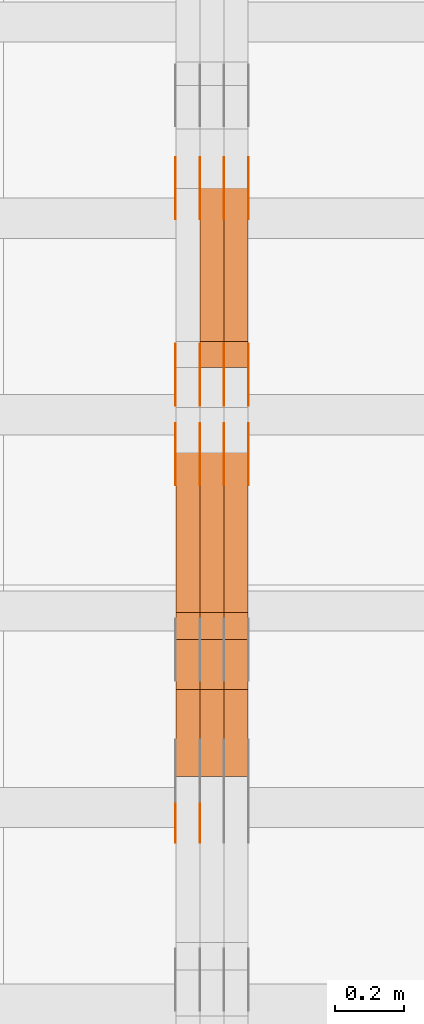
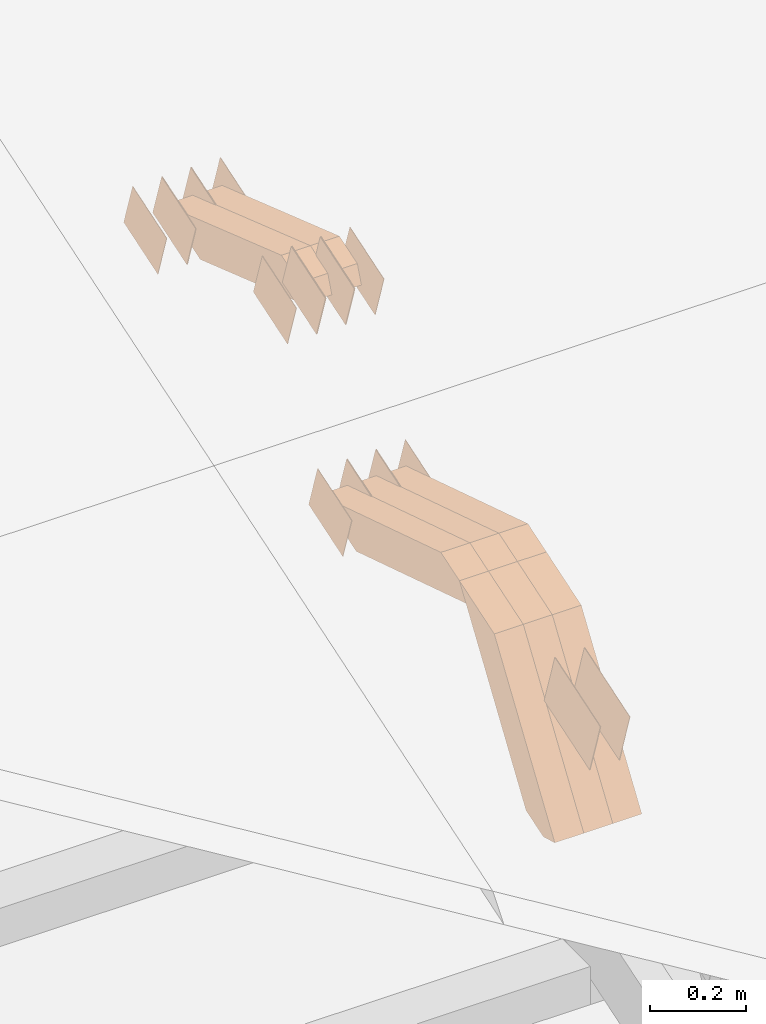
# One storey, part 127 of 385: 28 proxies.
"""IFC2X3 building model written with IfcOpenShell, lengths in millimetres."""

import ifcopenshell
import ifcopenshell.guid

model = None  # the IFC model being written
_history = None  # IfcOwnerHistory: only IFC2X3 demands one
_inside = {}  # id of a spatial element -> (the spatial element, [elements in it])
_under = {}  # id of a project, library or spatial element -> (it, [spatial elements below it])
_declared = {}  # id of a project -> (the project, [libraries it declares])
_typed = {}  # id of a type object -> (the type object, [elements of that type])
_made_of = {}  # id of a material, layer set ... -> (it, [elements and type objects made of it])


def new_model(schema):
    """Start an empty IFC model of exactly this schema.

    Asked for "IFC4X3", IfcOpenShell would pick the latest addendum, in which some entities
    have other attributes; the version numbers below select the first issue.
    IFC2X3 requires an IfcOwnerHistory on every rooted entity: one is made here for all.
    """
    global model, _history
    if schema == "IFC4X3":
        model = ifcopenshell.file(schema_version=(4, 3, 0, 0))
    else:
        model = ifcopenshell.file(schema=schema)
    _inside.clear()
    _under.clear()
    _declared.clear()
    _typed.clear()
    _made_of.clear()
    _history = None
    if model.schema == "IFC2X3":
        org = make("IfcOrganization", Name="unknown")
        user = make(
            "IfcPersonAndOrganization",
            ThePerson=make("IfcPerson", FamilyName="unknown"),
            TheOrganization=org,
        )
        app = make(
            "IfcApplication",
            ApplicationDeveloper=org,
            Version="unknown",
            ApplicationFullName="unknown",
            ApplicationIdentifier="unknown",
        )
        _history = make(
            "IfcOwnerHistory",
            OwningUser=user,
            OwningApplication=app,
            ChangeAction="ADDED",
            CreationDate=0,
        )
    return model


def make(cls, **values):
    """One entity of the class cls with the attributes given. An attribute that is None is left unset."""
    return model.create_entity(
        cls, **{name: value for name, value in values.items() if value is not None}
    )


def entity(cls, *values):
    """Any entity or typed value of the class cls, its attributes in the order of the schema. None: left unset."""
    e = model.create_entity(cls)
    for i, value in enumerate(values):
        if value is not None:
            e[i] = value
    return e


def rooted(cls, **values):
    """An entity with a GlobalId (a new one), such as an element, a storey or a relation."""
    return make(cls, GlobalId=ifcopenshell.guid.new(), OwnerHistory=_history, **values)


def si_unit(unit_type, name, prefix=None):
    """IfcSIUnit, for example si_unit("LENGTHUNIT", "METRE", prefix="MILLI")."""
    return make("IfcSIUnit", UnitType=unit_type, Prefix=prefix, Name=name)


def converted_unit(unit_type, name, factor, base, dimensions=None, offset=None):
    """IfcConversionBasedUnit, such as the inch: factor (a typed value) times the base unit."""
    return make(
        "IfcConversionBasedUnit"
        if offset is None
        else "IfcConversionBasedUnitWithOffset",
        ConversionOffset=offset,
        Dimensions=None
        if dimensions is None
        else entity("IfcDimensionalExponents", *dimensions),
        UnitType=unit_type,
        Name=name,
        ConversionFactor=make(
            "IfcMeasureWithUnit", ValueComponent=factor, UnitComponent=base
        ),
    )


def derived_unit(unit_type, elements):
    """IfcDerivedUnit: a product of units, each with its exponent."""
    return make(
        "IfcDerivedUnit",
        Elements=[
            make("IfcDerivedUnitElement", Unit=unit, Exponent=power)
            for unit, power in elements
        ],
        UnitType=unit_type,
    )


def assignment(units):
    """IfcUnitAssignment: the units of a project."""
    return None if units is None else make("IfcUnitAssignment", Units=units)


def point(xyz):
    """IfcCartesianPoint."""
    return None if xyz is None else make("IfcCartesianPoint", Coordinates=xyz)


def direction(xyz):
    """IfcDirection."""
    return None if xyz is None else make("IfcDirection", DirectionRatios=xyz)


def frame(location, z_axis=None, x_axis=None):
    """IfcAxis2Placement3D, a coordinate frame: its origin and axes. An axis left out is left unset."""
    return make(
        "IfcAxis2Placement3D",
        Location=point(location),
        Axis=direction(z_axis),
        RefDirection=direction(x_axis),
    )


def origin():
    """The frame at (0, 0, 0) with its axes left unset."""
    return frame((0.0, 0.0, 0.0))


def place(relative_to, where):
    """IfcLocalPlacement: puts the frame where relative to a parent placement (None: the world)."""
    return make(
        "IfcLocalPlacement", PlacementRelTo=relative_to, RelativePlacement=where
    )


def context(
    kind, dimensions, precision=None, world=None, true_north=None, identifier=None
):
    """IfcGeometricRepresentationContext, for example the 3D "Model" context."""
    return make(
        "IfcGeometricRepresentationContext",
        ContextIdentifier=identifier,
        ContextType=kind,
        CoordinateSpaceDimension=dimensions,
        Precision=precision,
        WorldCoordinateSystem=world,
        TrueNorth=true_north,
    )


def subcontext(parent, identifier, kind, view, scale=None):
    """IfcGeometricRepresentationSubContext, for example "Body" below "Model"."""
    return make(
        "IfcGeometricRepresentationSubContext",
        ContextIdentifier=identifier,
        ContextType=kind,
        ParentContext=parent,
        TargetScale=scale,
        TargetView=view,
    )


def project(units=None, contexts=None):
    """IfcProject with its units and contexts."""
    return rooted(
        "IfcProject",
        Name="project",
        RepresentationContexts=contexts,
        UnitsInContext=assignment(units),
    )


def spatial(cls, under=None, at=None, **own):
    """A site, building, storey or space (cls), placed at a placement, below another one or the project."""
    s = rooted(cls, ObjectPlacement=at, **own)
    if under is not None:
        _under.setdefault(under.id(), (under, []))[1].append(s)
    return s


def polyline(points):
    """IfcPolyline through the points."""
    return make("IfcPolyline", Points=[point(p) for p in points])


def outline(outer, holes=None, kind="AREA"):
    """IfcArbitraryClosedProfileDef: a profile drawn as a closed curve; with holes, ...WithVoids."""
    if holes is None:
        return make("IfcArbitraryClosedProfileDef", ProfileType=kind, OuterCurve=outer)
    return make(
        "IfcArbitraryProfileDefWithVoids",
        ProfileType=kind,
        OuterCurve=outer,
        InnerCurves=holes,
    )


def extrude(swept, where, along, depth):
    """IfcExtrudedAreaSolid: the profile swept, set in the frame where, extruded along a direction by depth."""
    return make(
        "IfcExtrudedAreaSolid",
        SweptArea=swept,
        Position=where,
        ExtrudedDirection=direction(along),
        Depth=depth,
    )


def shape(context_of_items, identifier, shape_type, items):
    """IfcShapeRepresentation: the items that make up one representation, for example the "Body"."""
    return make(
        "IfcShapeRepresentation",
        ContextOfItems=context_of_items,
        RepresentationIdentifier=identifier,
        RepresentationType=shape_type,
        Items=items,
    )


def source(mapping_origin, context_of_items, identifier, shape_type, items):
    """IfcRepresentationMap: a shape defined once, which mapped items show again and again."""
    return make(
        "IfcRepresentationMap",
        MappingOrigin=mapping_origin,
        MappedRepresentation=shape(context_of_items, identifier, shape_type, items),
    )


def transform(
    local_origin,
    x_axis=None,
    y_axis=None,
    z_axis=None,
    scale=None,
    scale2=None,
    scale3=None,
    uniform=True,
):
    """IfcCartesianTransformationOperator3D, or its non-uniform kind. x_axis, y_axis, z_axis: its Axis1, 2, 3."""
    if uniform:
        return make(
            "IfcCartesianTransformationOperator3D",
            Axis1=direction(x_axis),
            Axis2=direction(y_axis),
            LocalOrigin=point(local_origin),
            Scale=scale,
            Axis3=direction(z_axis),
        )
    return make(
        "IfcCartesianTransformationOperator3DnonUniform",
        Axis1=direction(x_axis),
        Axis2=direction(y_axis),
        LocalOrigin=point(local_origin),
        Scale=scale,
        Axis3=direction(z_axis),
        Scale2=scale2,
        Scale3=scale3,
    )


def mapped(mapping_source, mapping_target):
    """IfcMappedItem: shows the shape of a source again, moved by a transform."""
    return make(
        "IfcMappedItem", MappingSource=mapping_source, MappingTarget=mapping_target
    )


def material(Name=None, Category=None):
    """IfcMaterial."""
    return make("IfcMaterial", Name=Name, Category=Category)


def made_of(thing, what):
    """Note that an element or type object is made of a material, layer set ...; save() writes the relation."""
    if what is not None:
        _made_of.setdefault(what.id(), (what, []))[1].append(thing)
    return thing


def type_object(cls, material=None, **own):
    """A type object (cls), such as IfcWallType, which elements share."""
    return made_of(rooted(cls, **own), material)


def type_shapes(of_type, sources):
    """Give a type object the sources (RepresentationMaps) that its elements show as mapped items."""
    of_type.RepresentationMaps = sources


def element(
    cls,
    number,
    at=None,
    inside=None,
    cuts=None,
    type_object=None,
    material=None,
    context=None,
    identifier="Body",
    shape_type=None,
    held_by="IfcProductDefinitionShape",
    body=None,
    shapes=None,
    **own,
):
    """One element of the class cls, such as IfcWall. Its Tag is "e" and its number.

    at: its placement. inside: the storey or other place that contains it. cuts: it is an
    opening in that element (IfcRelVoidsElement). A single representation is given by context,
    identifier, shape_type and body (its items); several are given by shapes. held_by: the class
    of the entity that holds the representations. save() writes the other relations.
    """
    e = rooted(cls, Tag="e%d" % number, ObjectPlacement=at, **own)
    if body is not None:
        shapes = [shape(context, identifier, shape_type, body)]
    if shapes is not None:
        e.Representation = make(held_by, Representations=shapes)
    if inside is not None:
        _inside.setdefault(inside.id(), (inside, []))[1].append(e)
    if cuts is not None:
        rooted(
            "IfcRelVoidsElement", RelatingBuildingElement=cuts, RelatedOpeningElement=e
        )
    if type_object is not None:
        _typed.setdefault(type_object.id(), (type_object, []))[1].append(e)
    return made_of(e, material)


def aggregate(whole, parts):
    """IfcRelAggregates: a whole, such as a stair, and the parts it consists of."""
    return rooted("IfcRelAggregates", RelatingObject=whole, RelatedObjects=parts)


def save(model, path):
    """Write the relations noted so far, then the file.

    IfcRelAggregates (storeys below a building ...), IfcRelContainedInSpatialStructure (elements
    in a storey), IfcRelDefinesByType, IfcRelAssociatesMaterial and IfcRelDeclares: one each for
    every whole, place, type object, material and project.
    """
    for whole, parts in _under.values():
        aggregate(whole, parts)
    for where, things in _inside.values():
        rooted(
            "IfcRelContainedInSpatialStructure",
            RelatedElements=things,
            RelatingStructure=where,
        )
    for kind, things in _typed.values():
        rooted("IfcRelDefinesByType", RelatedObjects=things, RelatingType=kind)
    for what, things in _made_of.values():
        rooted("IfcRelAssociatesMaterial", RelatedObjects=things, RelatingMaterial=what)
    for by, libraries in _declared.values():
        rooted("IfcRelDeclares", RelatingContext=by, RelatedDefinitions=libraries)
    model.write(path)


model = new_model("IFC2X3")

# Units and contexts
model_context = context("Model", 3, precision=0.01, world=origin(), true_north=direction((6.12303176911189e-17, 1.0)))
body_context = subcontext(model_context, "Body", "Model", "MODEL_VIEW")
ifc_project = project(units=[si_unit("LENGTHUNIT", "METRE", prefix="MILLI"), si_unit("AREAUNIT", "SQUARE_METRE"), si_unit("VOLUMEUNIT", "CUBIC_METRE"), converted_unit("PLANEANGLEUNIT", "DEGREE", entity("IfcRatioMeasure", 0.0174532925199433), si_unit("PLANEANGLEUNIT", "RADIAN"), dimensions=[0, 0, 0, 0, 0, 0, 0]), si_unit("MASSUNIT", "GRAM", prefix="KILO"), derived_unit("MASSDENSITYUNIT", [(si_unit("MASSUNIT", "GRAM", prefix="KILO"), 1), (si_unit("LENGTHUNIT", "METRE"), -3)]), si_unit("TIMEUNIT", "SECOND"), si_unit("FREQUENCYUNIT", "HERTZ"), si_unit("THERMODYNAMICTEMPERATUREUNIT", "DEGREE_CELSIUS"), derived_unit("THERMALTRANSMITTANCEUNIT", [(si_unit("MASSUNIT", "GRAM", prefix="KILO"), 1), (si_unit("THERMODYNAMICTEMPERATUREUNIT", "KELVIN"), -1), (si_unit("TIMEUNIT", "SECOND"), -3)]), derived_unit("VOLUMETRICFLOWRATEUNIT", [(si_unit("LENGTHUNIT", "METRE"), 3), (si_unit("TIMEUNIT", "SECOND"), -1)]), si_unit("ELECTRICCURRENTUNIT", "AMPERE"), si_unit("ELECTRICVOLTAGEUNIT", "VOLT"), si_unit("POWERUNIT", "WATT"), si_unit("FORCEUNIT", "NEWTON", prefix="KILO"), si_unit("ILLUMINANCEUNIT", "LUX"), si_unit("LUMINOUSFLUXUNIT", "LUMEN"), si_unit("LUMINOUSINTENSITYUNIT", "CANDELA"), derived_unit("USERDEFINED", [(si_unit("MASSUNIT", "GRAM", prefix="KILO"), -1), (si_unit("LENGTHUNIT", "METRE"), -2), (si_unit("TIMEUNIT", "SECOND"), 3), (si_unit("LUMINOUSFLUXUNIT", "LUMEN"), 1)]), derived_unit("LINEARVELOCITYUNIT", [(si_unit("LENGTHUNIT", "METRE"), 1), (si_unit("TIMEUNIT", "SECOND"), -1)]), si_unit("PRESSUREUNIT", "PASCAL"), derived_unit("USERDEFINED", [(si_unit("LENGTHUNIT", "METRE"), -2), (si_unit("MASSUNIT", "GRAM", prefix="KILO"), 1), (si_unit("TIMEUNIT", "SECOND"), -2)])], contexts=[model_context])

# Site, building, storey
site_placement = place(None, origin())
site = spatial("IfcSite", under=ifc_project, at=site_placement, CompositionType="ELEMENT")
building_placement = place(site_placement, origin())
building = spatial("IfcBuilding", under=site, at=building_placement, CompositionType="ELEMENT")
storey_placement = place(building_placement, origin())
storey = spatial("IfcBuildingStorey", under=building, at=storey_placement, Name="Default", CompositionType="ELEMENT", Elevation=0.0)

# Proxies
ifc_material_1 = material(Name="IfcSurfaceStyle #345158")
building_element_proxy_type_1 = type_object("IfcBuildingElementProxyType", PredefinedType="NOTDEFINED", material=ifc_material_1)
shared_shape_1 = source(origin(), body_context, "Body", "SweptSolid", [
    extrude(outline(polyline([(-74.9998754286198, -60.0000016373433), (74.9998605591145, -60.0000016373433), (74.999875428618, 60.0000016373433), (-74.9998605591127, 60.0000016373433), (-74.9998754286198, -60.0000016373433)])), frame((75.0007059026038, 60.000210935219, 0.0), z_axis=(0.0, 0.0, 1.0), x_axis=(-1.0, 0.0, 0.0)), (0.0, 0.0, 1.0), 1.3),
])
type_shapes(building_element_proxy_type_1, [shared_shape_1])
proxy_1_placement = place(building_placement, frame((27386.3, 6760.15341914203, 1372.60670336718), z_axis=(-1.0, 0.0, 0.0), x_axis=(0.0, 0.951056516295124, 0.309016994375039)))
element("IfcBuildingElementProxy", 1, at=proxy_1_placement, inside=storey, type_object=building_element_proxy_type_1, material=ifc_material_1, context=body_context, shape_type="MappedRepresentation", body=[
    mapped(shared_shape_1, transform((0.0, 0.0, 0.0), scale=1.0)),
])
ifc_material_2 = material(Name="IfcSurfaceStyle #345101")
building_element_proxy_type_2 = type_object("IfcBuildingElementProxyType", PredefinedType="NOTDEFINED", material=ifc_material_2)
shared_shape_2 = source(origin(), body_context, "Body", "SweptSolid", [
    extrude(outline(polyline([(-74.9998754286198, -60.0000016373433), (74.9998605591145, -60.0000016373433), (74.999875428618, 60.0000016373433), (-74.9998605591127, 60.0000016373433), (-74.9998754286198, -60.0000016373433)])), frame((75.0007059026038, 60.000210935219, 0.0), z_axis=(0.0, 0.0, 1.0), x_axis=(-1.0, 0.0, 0.0)), (0.0, 0.0, 1.0), 1.3),
])
type_shapes(building_element_proxy_type_2, [shared_shape_2])
proxy_2_placement = place(building_placement, frame((27315.0, 6760.15341914203, 1372.60670336718), z_axis=(-1.0, 0.0, 0.0), x_axis=(0.0, 0.951056516295124, 0.309016994375039)))
element("IfcBuildingElementProxy", 2, at=proxy_2_placement, inside=storey, type_object=building_element_proxy_type_2, material=ifc_material_2, context=body_context, shape_type="MappedRepresentation", body=[
    mapped(shared_shape_2, transform((0.0, 0.0, 0.0), scale=1.0)),
])
ifc_material_3 = material(Name="IfcSurfaceStyle #345044")
building_element_proxy_type_3 = type_object("IfcBuildingElementProxyType", PredefinedType="NOTDEFINED", material=ifc_material_3)
shared_shape_3 = source(origin(), body_context, "Body", "SweptSolid", [
    extrude(outline(polyline([(-74.9998754286198, -60.0000016373433), (74.9998605591145, -60.0000016373433), (74.999875428618, 60.0000016373433), (-74.9998605591127, 60.0000016373433), (-74.9998754286198, -60.0000016373433)])), frame((75.0007059026038, 60.000210935219, 0.0), z_axis=(0.0, 0.0, 1.0), x_axis=(-1.0, 0.0, 0.0)), (0.0, 0.0, 1.0), 1.3),
])
type_shapes(building_element_proxy_type_3, [shared_shape_3])
proxy_3_placement = place(building_placement, frame((27316.3, 6760.15341914203, 1372.60670336718), z_axis=(-1.0, 0.0, 0.0), x_axis=(0.0, 0.951056516295124, 0.309016994375039)))
element("IfcBuildingElementProxy", 3, at=proxy_3_placement, inside=storey, type_object=building_element_proxy_type_3, material=ifc_material_3, context=body_context, shape_type="MappedRepresentation", body=[
    mapped(shared_shape_3, transform((0.0, 0.0, 0.0), scale=1.0)),
])
ifc_material_4 = material(Name="IfcSurfaceStyle #344987")
building_element_proxy_type_4 = type_object("IfcBuildingElementProxyType", PredefinedType="NOTDEFINED", material=ifc_material_4)
shared_shape_4 = source(origin(), body_context, "Body", "SweptSolid", [
    extrude(outline(polyline([(-74.9998754286198, -60.0000016373433), (74.9998605591145, -60.0000016373433), (74.999875428618, 60.0000016373433), (-74.9998605591127, 60.0000016373433), (-74.9998754286198, -60.0000016373433)])), frame((75.0007059026038, 60.000210935219, 0.0), z_axis=(0.0, 0.0, 1.0), x_axis=(-1.0, 0.0, 0.0)), (0.0, 0.0, 1.0), 1.29999999999999),
])
type_shapes(building_element_proxy_type_4, [shared_shape_4])
proxy_4_placement = place(building_placement, frame((27245.0, 6760.15341914203, 1372.60670336718), z_axis=(-1.0, 0.0, 0.0), x_axis=(0.0, 0.951056516295124, 0.309016994375039)))
element("IfcBuildingElementProxy", 4, at=proxy_4_placement, inside=storey, type_object=building_element_proxy_type_4, material=ifc_material_4, context=body_context, shape_type="MappedRepresentation", body=[
    mapped(shared_shape_4, transform((0.0, 0.0, 0.0), scale=1.0)),
])
ifc_material_5 = material(Name="IfcSurfaceStyle #344930")
building_element_proxy_type_5 = type_object("IfcBuildingElementProxyType", PredefinedType="NOTDEFINED", material=ifc_material_5)
shared_shape_5 = source(origin(), body_context, "Body", "SweptSolid", [
    extrude(outline(polyline([(-74.9998754286198, -60.0000016373433), (74.9998605591145, -60.0000016373433), (74.999875428618, 60.0000016373433), (-74.9998605591127, 60.0000016373433), (-74.9998754286198, -60.0000016373433)])), frame((75.0007059026038, 60.000210935219, 0.0), z_axis=(0.0, 0.0, 1.0), x_axis=(-1.0, 0.0, 0.0)), (0.0, 0.0, 1.0), 1.29999999999999),
])
type_shapes(building_element_proxy_type_5, [shared_shape_5])
proxy_5_placement = place(building_placement, frame((27246.3, 6760.15341914203, 1372.60670336718), z_axis=(-1.0, 0.0, 0.0), x_axis=(0.0, 0.951056516295124, 0.309016994375039)))
element("IfcBuildingElementProxy", 5, at=proxy_5_placement, inside=storey, type_object=building_element_proxy_type_5, material=ifc_material_5, context=body_context, shape_type="MappedRepresentation", body=[
    mapped(shared_shape_5, transform((0.0, 0.0, 0.0), scale=1.0)),
])
ifc_material_6 = material(Name="IfcSurfaceStyle #344873")
building_element_proxy_type_6 = type_object("IfcBuildingElementProxyType", PredefinedType="NOTDEFINED", material=ifc_material_6)
shared_shape_6 = source(origin(), body_context, "Body", "SweptSolid", [
    extrude(outline(polyline([(-74.9998754286198, -60.0000016373433), (74.9998605591145, -60.0000016373433), (74.999875428618, 60.0000016373433), (-74.9998605591127, 60.0000016373433), (-74.9998754286198, -60.0000016373433)])), frame((75.0007059026038, 60.000210935219, 0.0), z_axis=(0.0, 0.0, 1.0), x_axis=(-1.0, 0.0, 0.0)), (0.0, 0.0, 1.0), 1.29999999999999),
])
type_shapes(building_element_proxy_type_6, [shared_shape_6])
proxy_6_placement = place(building_placement, frame((27175.0, 6760.15341914203, 1372.60670336718), z_axis=(-1.0, 0.0, 0.0), x_axis=(0.0, 0.951056516295124, 0.309016994375039)))
element("IfcBuildingElementProxy", 6, at=proxy_6_placement, inside=storey, type_object=building_element_proxy_type_6, material=ifc_material_6, context=body_context, shape_type="MappedRepresentation", body=[
    mapped(shared_shape_6, transform((0.0, 0.0, 0.0), scale=1.0)),
])
ifc_material_7 = material(Name="IfcSurfaceStyle #339002")
building_element_proxy_type_7 = type_object("IfcBuildingElementProxyType", PredefinedType="NOTDEFINED", material=ifc_material_7)
shared_shape_7 = source(origin(), body_context, "Body", "SweptSolid", [
    extrude(outline(polyline([(-74.9998801438441, -60.0000306612856), (74.9998747047876, -60.0000306612856), (74.9998707133936, 60.0000306612856), (-74.9998652743371, 60.0000306612856), (-74.9998801438441, -60.0000306612856)])), frame((75.0000206139493, 60.0000306612856, 0.0), z_axis=(0.0, 0.0, 1.0), x_axis=(-1.0, 0.0, 0.0)), (0.0, 0.0, 1.0), 1.3),
])
type_shapes(building_element_proxy_type_7, [shared_shape_7])
proxy_7_placement = place(building_placement, frame((27386.3, 5987.08381858242, 1121.42116774683), z_axis=(-1.0, 0.0, 0.0), x_axis=(0.0, 0.951056516295124, 0.309016994375039)))
element("IfcBuildingElementProxy", 7, at=proxy_7_placement, inside=storey, type_object=building_element_proxy_type_7, material=ifc_material_7, context=body_context, shape_type="MappedRepresentation", body=[
    mapped(shared_shape_7, transform((0.0, 0.0, 0.0), scale=1.0)),
])
ifc_material_8 = material(Name="IfcSurfaceStyle #338945")
building_element_proxy_type_8 = type_object("IfcBuildingElementProxyType", PredefinedType="NOTDEFINED", material=ifc_material_8)
shared_shape_8 = source(origin(), body_context, "Body", "SweptSolid", [
    extrude(outline(polyline([(-74.9998801438441, -60.0000306612856), (74.9998747047876, -60.0000306612856), (74.9998707133936, 60.0000306612856), (-74.9998652743371, 60.0000306612856), (-74.9998801438441, -60.0000306612856)])), frame((75.0000206139493, 60.0000306612856, 0.0), z_axis=(0.0, 0.0, 1.0), x_axis=(-1.0, 0.0, 0.0)), (0.0, 0.0, 1.0), 1.3),
])
type_shapes(building_element_proxy_type_8, [shared_shape_8])
proxy_8_placement = place(building_placement, frame((27315.0, 5987.08381858242, 1121.42116774683), z_axis=(-1.0, 0.0, 0.0), x_axis=(0.0, 0.951056516295124, 0.309016994375039)))
element("IfcBuildingElementProxy", 8, at=proxy_8_placement, inside=storey, type_object=building_element_proxy_type_8, material=ifc_material_8, context=body_context, shape_type="MappedRepresentation", body=[
    mapped(shared_shape_8, transform((0.0, 0.0, 0.0), scale=1.0)),
])
ifc_material_9 = material(Name="IfcSurfaceStyle #338888")
building_element_proxy_type_9 = type_object("IfcBuildingElementProxyType", PredefinedType="NOTDEFINED", material=ifc_material_9)
shared_shape_9 = source(origin(), body_context, "Body", "SweptSolid", [
    extrude(outline(polyline([(-74.9998801438441, -60.0000306612856), (74.9998747047876, -60.0000306612856), (74.9998707133936, 60.0000306612856), (-74.9998652743371, 60.0000306612856), (-74.9998801438441, -60.0000306612856)])), frame((75.0000206139493, 60.0000306612856, 0.0), z_axis=(0.0, 0.0, 1.0), x_axis=(-1.0, 0.0, 0.0)), (0.0, 0.0, 1.0), 1.3),
])
type_shapes(building_element_proxy_type_9, [shared_shape_9])
proxy_9_placement = place(building_placement, frame((27316.3, 5987.08381858242, 1121.42116774683), z_axis=(-1.0, 0.0, 0.0), x_axis=(0.0, 0.951056516295124, 0.309016994375039)))
element("IfcBuildingElementProxy", 9, at=proxy_9_placement, inside=storey, type_object=building_element_proxy_type_9, material=ifc_material_9, context=body_context, shape_type="MappedRepresentation", body=[
    mapped(shared_shape_9, transform((0.0, 0.0, 0.0), scale=1.0)),
])
ifc_material_10 = material(Name="IfcSurfaceStyle #338831")
building_element_proxy_type_10 = type_object("IfcBuildingElementProxyType", PredefinedType="NOTDEFINED", material=ifc_material_10)
shared_shape_10 = source(origin(), body_context, "Body", "SweptSolid", [
    extrude(outline(polyline([(-74.9998801438441, -60.0000306612856), (74.9998747047876, -60.0000306612856), (74.9998707133936, 60.0000306612856), (-74.9998652743371, 60.0000306612856), (-74.9998801438441, -60.0000306612856)])), frame((75.0000206139493, 60.0000306612856, 0.0), z_axis=(0.0, 0.0, 1.0), x_axis=(-1.0, 0.0, 0.0)), (0.0, 0.0, 1.0), 1.29999999999999),
])
type_shapes(building_element_proxy_type_10, [shared_shape_10])
proxy_10_placement = place(building_placement, frame((27245.0, 5987.08381858242, 1121.42116774683), z_axis=(-1.0, 0.0, 0.0), x_axis=(0.0, 0.951056516295124, 0.309016994375039)))
element("IfcBuildingElementProxy", 10, at=proxy_10_placement, inside=storey, type_object=building_element_proxy_type_10, material=ifc_material_10, context=body_context, shape_type="MappedRepresentation", body=[
    mapped(shared_shape_10, transform((0.0, 0.0, 0.0), scale=1.0)),
])
ifc_material_11 = material(Name="IfcSurfaceStyle #338774")
building_element_proxy_type_11 = type_object("IfcBuildingElementProxyType", PredefinedType="NOTDEFINED", material=ifc_material_11)
shared_shape_11 = source(origin(), body_context, "Body", "SweptSolid", [
    extrude(outline(polyline([(-74.9998801438441, -60.0000306612856), (74.9998747047876, -60.0000306612856), (74.9998707133936, 60.0000306612856), (-74.9998652743371, 60.0000306612856), (-74.9998801438441, -60.0000306612856)])), frame((75.0000206139493, 60.0000306612856, 0.0), z_axis=(0.0, 0.0, 1.0), x_axis=(-1.0, 0.0, 0.0)), (0.0, 0.0, 1.0), 1.29999999999999),
])
type_shapes(building_element_proxy_type_11, [shared_shape_11])
proxy_11_placement = place(building_placement, frame((27246.3, 5987.08381858242, 1121.42116774683), z_axis=(-1.0, 0.0, 0.0), x_axis=(0.0, 0.951056516295124, 0.309016994375039)))
element("IfcBuildingElementProxy", 11, at=proxy_11_placement, inside=storey, type_object=building_element_proxy_type_11, material=ifc_material_11, context=body_context, shape_type="MappedRepresentation", body=[
    mapped(shared_shape_11, transform((0.0, 0.0, 0.0), scale=1.0)),
])
ifc_material_12 = material(Name="IfcSurfaceStyle #338717")
building_element_proxy_type_12 = type_object("IfcBuildingElementProxyType", PredefinedType="NOTDEFINED", material=ifc_material_12)
shared_shape_12 = source(origin(), body_context, "Body", "SweptSolid", [
    extrude(outline(polyline([(-74.9998801438441, -60.0000306612856), (74.9998747047876, -60.0000306612856), (74.9998707133936, 60.0000306612856), (-74.9998652743371, 60.0000306612856), (-74.9998801438441, -60.0000306612856)])), frame((75.0000206139493, 60.0000306612856, 0.0), z_axis=(0.0, 0.0, 1.0), x_axis=(-1.0, 0.0, 0.0)), (0.0, 0.0, 1.0), 1.29999999999999),
])
type_shapes(building_element_proxy_type_12, [shared_shape_12])
proxy_12_placement = place(building_placement, frame((27175.0, 5987.08381858242, 1121.42116774683), z_axis=(-1.0, 0.0, 0.0), x_axis=(0.0, 0.951056516295124, 0.309016994375039)))
element("IfcBuildingElementProxy", 12, at=proxy_12_placement, inside=storey, type_object=building_element_proxy_type_12, material=ifc_material_12, context=body_context, shape_type="MappedRepresentation", body=[
    mapped(shared_shape_12, transform((0.0, 0.0, 0.0), scale=1.0)),
])
ifc_material_13 = material(Name="IfcSurfaceStyle #334556")
building_element_proxy_type_13 = type_object("IfcBuildingElementProxyType", PredefinedType="NOTDEFINED", material=ifc_material_13)
shared_shape_13 = source(origin(), body_context, "Body", "SweptSolid", [
    extrude(outline(polyline([(-74.9998754286253, -60.0000016373506), (74.999860559109, -60.0000016373506), (74.9998754286235, 60.0000016373506), (-74.9998605591072, 60.0000016373506), (-74.9998754286253, -60.0000016373506)])), frame((75.0001009411744, 60.0000279841752, 0.0), z_axis=(0.0, 0.0, 1.0), x_axis=(-1.0, 0.0, 0.0)), (0.0, 0.0, 1.0), 1.3),
])
type_shapes(building_element_proxy_type_13, [shared_shape_13])
proxy_13_placement = place(building_placement, frame((27386.3, 6218.29662915452, 1523.23574463408), z_axis=(-1.0, 0.0, 0.0), x_axis=(0.0, 0.951056516295154, 0.309016994374948)))
element("IfcBuildingElementProxy", 13, at=proxy_13_placement, inside=storey, type_object=building_element_proxy_type_13, material=ifc_material_13, context=body_context, shape_type="MappedRepresentation", body=[
    mapped(shared_shape_13, transform((0.0, 0.0, 0.0), scale=1.0)),
])
ifc_material_14 = material(Name="IfcSurfaceStyle #334499")
building_element_proxy_type_14 = type_object("IfcBuildingElementProxyType", PredefinedType="NOTDEFINED", material=ifc_material_14)
shared_shape_14 = source(origin(), body_context, "Body", "SweptSolid", [
    extrude(outline(polyline([(-74.9998754286253, -60.0000016373506), (74.999860559109, -60.0000016373506), (74.9998754286235, 60.0000016373506), (-74.9998605591072, 60.0000016373506), (-74.9998754286253, -60.0000016373506)])), frame((75.0001009411744, 60.0000279841752, 0.0), z_axis=(0.0, 0.0, 1.0), x_axis=(-1.0, 0.0, 0.0)), (0.0, 0.0, 1.0), 1.3),
])
type_shapes(building_element_proxy_type_14, [shared_shape_14])
proxy_14_placement = place(building_placement, frame((27315.0, 6218.29662915452, 1523.23574463408), z_axis=(-1.0, 0.0, 0.0), x_axis=(0.0, 0.951056516295154, 0.309016994374948)))
element("IfcBuildingElementProxy", 14, at=proxy_14_placement, inside=storey, type_object=building_element_proxy_type_14, material=ifc_material_14, context=body_context, shape_type="MappedRepresentation", body=[
    mapped(shared_shape_14, transform((0.0, 0.0, 0.0), scale=1.0)),
])
ifc_material_15 = material(Name="IfcSurfaceStyle #334442")
building_element_proxy_type_15 = type_object("IfcBuildingElementProxyType", PredefinedType="NOTDEFINED", material=ifc_material_15)
shared_shape_15 = source(origin(), body_context, "Body", "SweptSolid", [
    extrude(outline(polyline([(-74.9998754286253, -60.0000016373506), (74.999860559109, -60.0000016373506), (74.9998754286235, 60.0000016373506), (-74.9998605591072, 60.0000016373506), (-74.9998754286253, -60.0000016373506)])), frame((75.0001009411744, 60.0000279841752, 0.0), z_axis=(0.0, 0.0, 1.0), x_axis=(-1.0, 0.0, 0.0)), (0.0, 0.0, 1.0), 1.3),
])
type_shapes(building_element_proxy_type_15, [shared_shape_15])
proxy_15_placement = place(building_placement, frame((27316.3, 6218.29662915452, 1523.23574463408), z_axis=(-1.0, 0.0, 0.0), x_axis=(0.0, 0.951056516295154, 0.309016994374948)))
element("IfcBuildingElementProxy", 15, at=proxy_15_placement, inside=storey, type_object=building_element_proxy_type_15, material=ifc_material_15, context=body_context, shape_type="MappedRepresentation", body=[
    mapped(shared_shape_15, transform((0.0, 0.0, 0.0), scale=1.0)),
])
ifc_material_16 = material(Name="IfcSurfaceStyle #334385")
building_element_proxy_type_16 = type_object("IfcBuildingElementProxyType", PredefinedType="NOTDEFINED", material=ifc_material_16)
shared_shape_16 = source(origin(), body_context, "Body", "SweptSolid", [
    extrude(outline(polyline([(-74.9998754286253, -60.0000016373506), (74.999860559109, -60.0000016373506), (74.9998754286235, 60.0000016373506), (-74.9998605591072, 60.0000016373506), (-74.9998754286253, -60.0000016373506)])), frame((75.0001009411744, 60.0000279841752, 0.0), z_axis=(0.0, 0.0, 1.0), x_axis=(-1.0, 0.0, 0.0)), (0.0, 0.0, 1.0), 1.29999999999999),
])
type_shapes(building_element_proxy_type_16, [shared_shape_16])
proxy_16_placement = place(building_placement, frame((27245.0, 6218.29662915452, 1523.23574463408), z_axis=(-1.0, 0.0, 0.0), x_axis=(0.0, 0.951056516295154, 0.309016994374948)))
element("IfcBuildingElementProxy", 16, at=proxy_16_placement, inside=storey, type_object=building_element_proxy_type_16, material=ifc_material_16, context=body_context, shape_type="MappedRepresentation", body=[
    mapped(shared_shape_16, transform((0.0, 0.0, 0.0), scale=1.0)),
])
ifc_material_17 = material(Name="IfcSurfaceStyle #334328")
building_element_proxy_type_17 = type_object("IfcBuildingElementProxyType", PredefinedType="NOTDEFINED", material=ifc_material_17)
shared_shape_17 = source(origin(), body_context, "Body", "SweptSolid", [
    extrude(outline(polyline([(-74.9998754286253, -60.0000016373506), (74.999860559109, -60.0000016373506), (74.9998754286235, 60.0000016373506), (-74.9998605591072, 60.0000016373506), (-74.9998754286253, -60.0000016373506)])), frame((75.0001009411744, 60.0000279841752, 0.0), z_axis=(0.0, 0.0, 1.0), x_axis=(-1.0, 0.0, 0.0)), (0.0, 0.0, 1.0), 1.29999999999999),
])
type_shapes(building_element_proxy_type_17, [shared_shape_17])
proxy_17_placement = place(building_placement, frame((27246.3, 6218.29662915452, 1523.23574463408), z_axis=(-1.0, 0.0, 0.0), x_axis=(0.0, 0.951056516295154, 0.309016994374948)))
element("IfcBuildingElementProxy", 17, at=proxy_17_placement, inside=storey, type_object=building_element_proxy_type_17, material=ifc_material_17, context=body_context, shape_type="MappedRepresentation", body=[
    mapped(shared_shape_17, transform((0.0, 0.0, 0.0), scale=1.0)),
])
ifc_material_18 = material(Name="IfcSurfaceStyle #334271")
building_element_proxy_type_18 = type_object("IfcBuildingElementProxyType", PredefinedType="NOTDEFINED", material=ifc_material_18)
shared_shape_18 = source(origin(), body_context, "Body", "SweptSolid", [
    extrude(outline(polyline([(-74.9998754286253, -60.0000016373506), (74.999860559109, -60.0000016373506), (74.9998754286235, 60.0000016373506), (-74.9998605591072, 60.0000016373506), (-74.9998754286253, -60.0000016373506)])), frame((75.0001009411744, 60.0000279841752, 0.0), z_axis=(0.0, 0.0, 1.0), x_axis=(-1.0, 0.0, 0.0)), (0.0, 0.0, 1.0), 1.29999999999999),
])
type_shapes(building_element_proxy_type_18, [shared_shape_18])
proxy_18_placement = place(building_placement, frame((27175.0, 6218.29662915452, 1523.23574463408), z_axis=(-1.0, 0.0, 0.0), x_axis=(0.0, 0.951056516295154, 0.309016994374948)))
element("IfcBuildingElementProxy", 18, at=proxy_18_placement, inside=storey, type_object=building_element_proxy_type_18, material=ifc_material_18, context=body_context, shape_type="MappedRepresentation", body=[
    mapped(shared_shape_18, transform((0.0, 0.0, 0.0), scale=1.0)),
])
ifc_material_19 = material(Name="IfcSurfaceStyle #329882")
building_element_proxy_type_19 = type_object("IfcBuildingElementProxyType", PredefinedType="NOTDEFINED", material=ifc_material_19)
shared_shape_19 = source(origin(), body_context, "Body", "SweptSolid", [
    extrude(outline(polyline([(-99.9996257846169, -71.999973710258), (100.000009625089, -71.999973710258), (99.9996257846187, 71.999973710258), (-100.000009625091, 71.999973710258), (-99.9996257846169, -71.999973710258)])), frame((100.000083496635, 72.0000008245779, 0.0), z_axis=(0.0, 0.0, 1.0), x_axis=(-1.0, 0.0, 0.0)), (0.0, 0.0, 1.0), 1.29999999999998),
])
type_shapes(building_element_proxy_type_19, [shared_shape_19])
proxy_19_placement = place(building_placement, frame((27246.3, 4947.73195917317, 1225.53937157357), z_axis=(-1.0, 0.0, 0.0), x_axis=(0.0, 0.951056516295154, 0.309016994374948)))
element("IfcBuildingElementProxy", 19, at=proxy_19_placement, inside=storey, type_object=building_element_proxy_type_19, material=ifc_material_19, context=body_context, shape_type="MappedRepresentation", body=[
    mapped(shared_shape_19, transform((0.0, 0.0, 0.0), scale=1.0)),
])
ifc_material_20 = material(Name="IfcSurfaceStyle #329825")
building_element_proxy_type_20 = type_object("IfcBuildingElementProxyType", PredefinedType="NOTDEFINED", material=ifc_material_20)
shared_shape_20 = source(origin(), body_context, "Body", "SweptSolid", [
    extrude(outline(polyline([(-99.9996257846169, -71.999973710258), (100.000009625089, -71.999973710258), (99.9996257846187, 71.999973710258), (-100.000009625091, 71.999973710258), (-99.9996257846169, -71.999973710258)])), frame((100.000083496635, 72.0000008245779, 0.0), z_axis=(0.0, 0.0, 1.0), x_axis=(-1.0, 0.0, 0.0)), (0.0, 0.0, 1.0), 1.29999999999999),
])
type_shapes(building_element_proxy_type_20, [shared_shape_20])
proxy_20_placement = place(building_placement, frame((27175.0, 4947.73195917317, 1225.53937157357), z_axis=(-1.0, 0.0, 0.0), x_axis=(0.0, 0.951056516295154, 0.309016994374948)))
element("IfcBuildingElementProxy", 20, at=proxy_20_placement, inside=storey, type_object=building_element_proxy_type_20, material=ifc_material_20, context=body_context, shape_type="MappedRepresentation", body=[
    mapped(shared_shape_20, transform((0.0, 0.0, 0.0), scale=1.0)),
])
ifc_material_21 = material(Name="IfcSurfaceStyle #321560")
building_element_proxy_type_21 = type_object("IfcBuildingElementProxyType", Name="T1-W19 321558", PredefinedType="NOTDEFINED", material=ifc_material_21)
shared_shape_21 = source(origin(), body_context, "Body", "SweptSolid", [
    extrude(outline(polyline([(-234.986199656822, -47.5000587840676), (221.224626701627, -47.5000587840676), (219.29748584664, -9.04449542012076e-05), (156.014457007826, 47.5001040065446), (-361.550369899272, 47.5001040065447), (-234.986199656822, -47.5000587840676)])), frame((221.224626701627, 47.5001108598228, 0.0), z_axis=(0.0, 0.0, 1.0), x_axis=(-1.0, 0.0, 0.0)), (0.0, 0.0, 1.0), 70.0),
])
type_shapes(building_element_proxy_type_21, [shared_shape_21])
proxy_21_placement = place(building_placement, frame((27385.0, 6342.4042570111, 1541.63383639481), z_axis=(-1.0, 0.0, 0.0), x_axis=(0.0, 0.9461301511345, -0.323786561046329)))
element("IfcBuildingElementProxy", 21, at=proxy_21_placement, inside=storey, type_object=building_element_proxy_type_21, material=ifc_material_21, Name="T1-W19", context=body_context, shape_type="MappedRepresentation", body=[
    mapped(shared_shape_21, transform((0.0, 0.0, 0.0), scale=1.0)),
])
ifc_material_22 = material(Name="IfcSurfaceStyle #321494")
building_element_proxy_type_22 = type_object("IfcBuildingElementProxyType", Name="T1-W19 321492", PredefinedType="NOTDEFINED", material=ifc_material_22)
shared_shape_22 = source(origin(), body_context, "Body", "SweptSolid", [
    extrude(outline(polyline([(-234.986199656822, -47.5000587840676), (221.224626701627, -47.5000587840676), (219.29748584664, -9.04449542012076e-05), (156.014457007826, 47.5001040065446), (-361.550369899272, 47.5001040065447), (-234.986199656822, -47.5000587840676)])), frame((221.224626701627, 47.5001108598228, 0.0), z_axis=(0.0, 0.0, 1.0), x_axis=(-1.0, 0.0, 0.0)), (0.0, 0.0, 1.0), 70.0),
])
type_shapes(building_element_proxy_type_22, [shared_shape_22])
proxy_22_placement = place(building_placement, frame((27315.0, 6342.4042570111, 1541.63383639481), z_axis=(-1.0, 0.0, 0.0), x_axis=(0.0, 0.9461301511345, -0.323786561046329)))
element("IfcBuildingElementProxy", 22, at=proxy_22_placement, inside=storey, type_object=building_element_proxy_type_22, material=ifc_material_22, Name="T1-W19", context=body_context, shape_type="MappedRepresentation", body=[
    mapped(shared_shape_22, transform((0.0, 0.0, 0.0), scale=1.0)),
])
ifc_material_23 = material(Name="IfcSurfaceStyle #320768")
building_element_proxy_type_23 = type_object("IfcBuildingElementProxyType", Name="T1-W15 320766", PredefinedType="NOTDEFINED", material=ifc_material_23)
shared_shape_23 = source(origin(), body_context, "Body", "SweptSolid", [
    extrude(outline(polyline([(-243.398341390642, -47.5000170814535), (237.775741169608, -47.5000170814535), (224.054017709933, 0.000127777485579883), (157.692261395711, 47.4999531927108), (-376.12367888461, 47.4999531927107), (-243.398341390642, -47.5000170814535)])), frame((237.77637044506, 47.5003404768297, 0.0), z_axis=(0.0, 0.0, 1.0), x_axis=(-1.0, 0.0, 0.0)), (0.0, 0.0, 1.0), 70.0),
])
type_shapes(building_element_proxy_type_23, [shared_shape_23])
proxy_23_placement = place(building_placement, frame((27385.0, 5540.23242178142, 1288.84274826279), z_axis=(-1.0, 0.0, 0.0), x_axis=(0.0, 0.95322291386448, -0.302268219440466)))
element("IfcBuildingElementProxy", 23, at=proxy_23_placement, inside=storey, type_object=building_element_proxy_type_23, material=ifc_material_23, Name="T1-W15", context=body_context, shape_type="MappedRepresentation", body=[
    mapped(shared_shape_23, transform((0.0, 0.0, 0.0), scale=1.0)),
])
ifc_material_24 = material(Name="IfcSurfaceStyle #320702")
building_element_proxy_type_24 = type_object("IfcBuildingElementProxyType", Name="T1-W15 320700", PredefinedType="NOTDEFINED", material=ifc_material_24)
shared_shape_24 = source(origin(), body_context, "Body", "SweptSolid", [
    extrude(outline(polyline([(-243.398341390642, -47.5000170814535), (237.775741169608, -47.5000170814535), (224.054017709933, 0.000127777485579883), (157.692261395711, 47.4999531927108), (-376.12367888461, 47.4999531927107), (-243.398341390642, -47.5000170814535)])), frame((237.77637044506, 47.5003404768297, 0.0), z_axis=(0.0, 0.0, 1.0), x_axis=(-1.0, 0.0, 0.0)), (0.0, 0.0, 1.0), 70.0),
])
type_shapes(building_element_proxy_type_24, [shared_shape_24])
proxy_24_placement = place(building_placement, frame((27315.0, 5540.23242178142, 1288.84274826279), z_axis=(-1.0, 0.0, 0.0), x_axis=(0.0, 0.95322291386448, -0.302268219440466)))
element("IfcBuildingElementProxy", 24, at=proxy_24_placement, inside=storey, type_object=building_element_proxy_type_24, material=ifc_material_24, Name="T1-W15", context=body_context, shape_type="MappedRepresentation", body=[
    mapped(shared_shape_24, transform((0.0, 0.0, 0.0), scale=1.0)),
])
ifc_material_25 = material(Name="IfcSurfaceStyle #320636")
building_element_proxy_type_25 = type_object("IfcBuildingElementProxyType", Name="T1-W15 320634", PredefinedType="NOTDEFINED", material=ifc_material_25)
shared_shape_25 = source(origin(), body_context, "Body", "SweptSolid", [
    extrude(outline(polyline([(-243.398341390642, -47.5000170814535), (237.775741169608, -47.5000170814535), (224.054017709933, 0.000127777485579883), (157.692261395711, 47.4999531927108), (-376.12367888461, 47.4999531927107), (-243.398341390642, -47.5000170814535)])), frame((237.77637044506, 47.5003404768297, 0.0), z_axis=(0.0, 0.0, 1.0), x_axis=(-1.0, 0.0, 0.0)), (0.0, 0.0, 1.0), 70.0),
])
type_shapes(building_element_proxy_type_25, [shared_shape_25])
proxy_25_placement = place(building_placement, frame((27245.0, 5540.23242178142, 1288.84274826279), z_axis=(-1.0, 0.0, 0.0), x_axis=(0.0, 0.95322291386448, -0.302268219440466)))
element("IfcBuildingElementProxy", 25, at=proxy_25_placement, inside=storey, type_object=building_element_proxy_type_25, material=ifc_material_25, Name="T1-W15", context=body_context, shape_type="MappedRepresentation", body=[
    mapped(shared_shape_25, transform((0.0, 0.0, 0.0), scale=1.0)),
])
ifc_material_26 = material(Name="IfcSurfaceStyle #320372")
building_element_proxy_type_26 = type_object("IfcBuildingElementProxyType", Name="T1-W22 320370", PredefinedType="NOTDEFINED", material=ifc_material_26)
shared_shape_26 = source(origin(), body_context, "Body", "SweptSolid", [
    extrude(outline(polyline([(-351.940486061686, -47.5005995570677), (149.451602529695, -47.5005995570676), (209.614029773051, 0.000108554198836676), (224.491670779786, 47.5010029530092), (-231.616817020846, 47.5000876069273), (-351.940486061686, -47.5005995570677)])), frame((224.491766107217, 47.5005524294596, 0.0), z_axis=(0.0, 0.0, 1.0), x_axis=(-1.0, 2.00686044286885e-06, 0.0)), (0.0, 0.0, 1.0), 70.0),
])
type_shapes(building_element_proxy_type_26, [shared_shape_26])
proxy_26_placement = place(building_placement, frame((27385.0, 5140.03125000001, 812.615600585936), z_axis=(-1.0, 0.0, 0.0), x_axis=(0.0, 0.554956576676696, 0.831879316970486)))
element("IfcBuildingElementProxy", 26, at=proxy_26_placement, inside=storey, type_object=building_element_proxy_type_26, material=ifc_material_26, Name="T1-W22", context=body_context, shape_type="MappedRepresentation", body=[
    mapped(shared_shape_26, transform((0.0, 0.0, 0.0), scale=1.0)),
])
ifc_material_27 = material(Name="IfcSurfaceStyle #320306")
building_element_proxy_type_27 = type_object("IfcBuildingElementProxyType", Name="T1-W22 320304", PredefinedType="NOTDEFINED", material=ifc_material_27)
shared_shape_27 = source(origin(), body_context, "Body", "SweptSolid", [
    extrude(outline(polyline([(-351.940486061686, -47.5005995570677), (149.451602529695, -47.5005995570676), (209.614029773051, 0.000108554198836676), (224.491670779786, 47.5010029530092), (-231.616817020846, 47.5000876069273), (-351.940486061686, -47.5005995570677)])), frame((224.491766107217, 47.5005524294596, 0.0), z_axis=(0.0, 0.0, 1.0), x_axis=(-1.0, 2.00686044286885e-06, 0.0)), (0.0, 0.0, 1.0), 70.0),
])
type_shapes(building_element_proxy_type_27, [shared_shape_27])
proxy_27_placement = place(building_placement, frame((27315.0, 5140.03125000001, 812.615600585936), z_axis=(-1.0, 0.0, 0.0), x_axis=(0.0, 0.554956576676696, 0.831879316970486)))
element("IfcBuildingElementProxy", 27, at=proxy_27_placement, inside=storey, type_object=building_element_proxy_type_27, material=ifc_material_27, Name="T1-W22", context=body_context, shape_type="MappedRepresentation", body=[
    mapped(shared_shape_27, transform((0.0, 0.0, 0.0), scale=1.0)),
])
ifc_material_28 = material(Name="IfcSurfaceStyle #320240")
building_element_proxy_type_28 = type_object("IfcBuildingElementProxyType", Name="T1-W22 320238", PredefinedType="NOTDEFINED", material=ifc_material_28)
shared_shape_28 = source(origin(), body_context, "Body", "SweptSolid", [
    extrude(outline(polyline([(-351.940486061686, -47.5005995570677), (149.451602529695, -47.5005995570676), (209.614029773051, 0.000108554198836676), (224.491670779786, 47.5010029530092), (-231.616817020846, 47.5000876069273), (-351.940486061686, -47.5005995570677)])), frame((224.491766107217, 47.5005524294596, 0.0), z_axis=(0.0, 0.0, 1.0), x_axis=(-1.0, 2.00686044286885e-06, 0.0)), (0.0, 0.0, 1.0), 70.0),
])
type_shapes(building_element_proxy_type_28, [shared_shape_28])
proxy_28_placement = place(building_placement, frame((27245.0, 5140.03125000001, 812.615600585936), z_axis=(-1.0, 0.0, 0.0), x_axis=(0.0, 0.554956576676696, 0.831879316970486)))
element("IfcBuildingElementProxy", 28, at=proxy_28_placement, inside=storey, type_object=building_element_proxy_type_28, material=ifc_material_28, Name="T1-W22", context=body_context, shape_type="MappedRepresentation", body=[
    mapped(shared_shape_28, transform((0.0, 0.0, 0.0), scale=1.0)),
])

save(model, "model.ifc")
